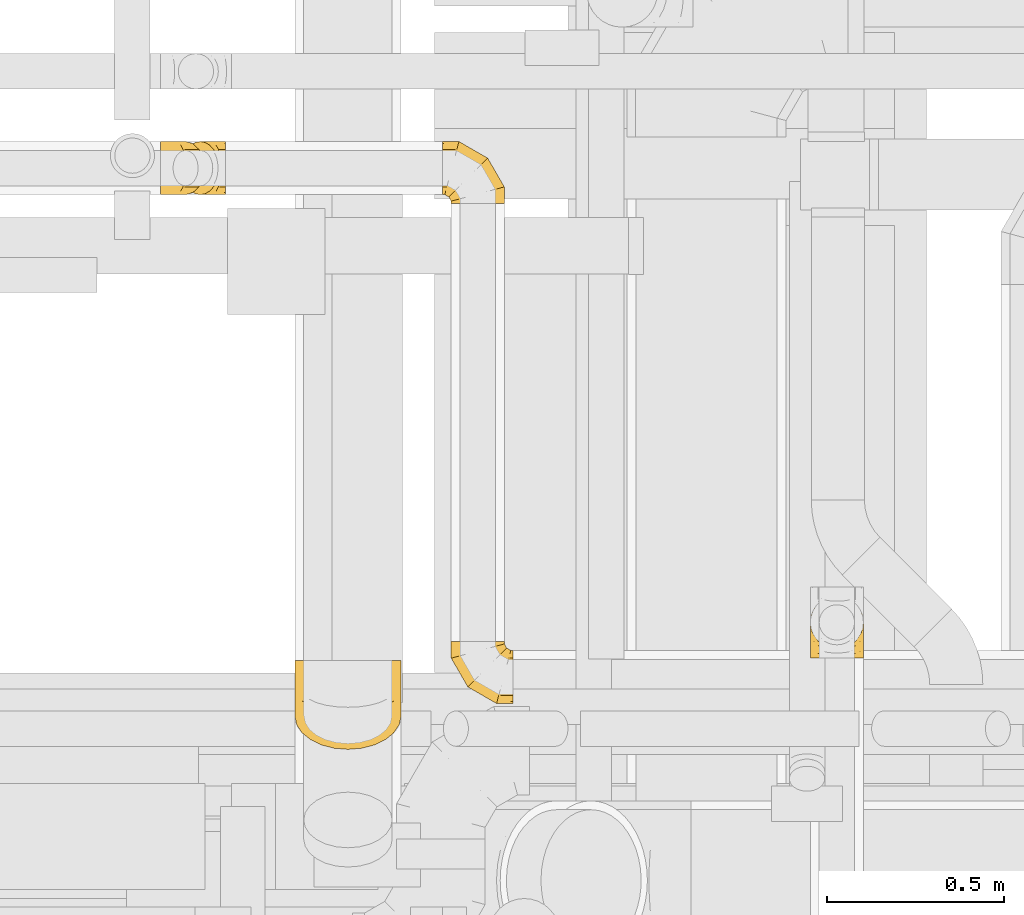
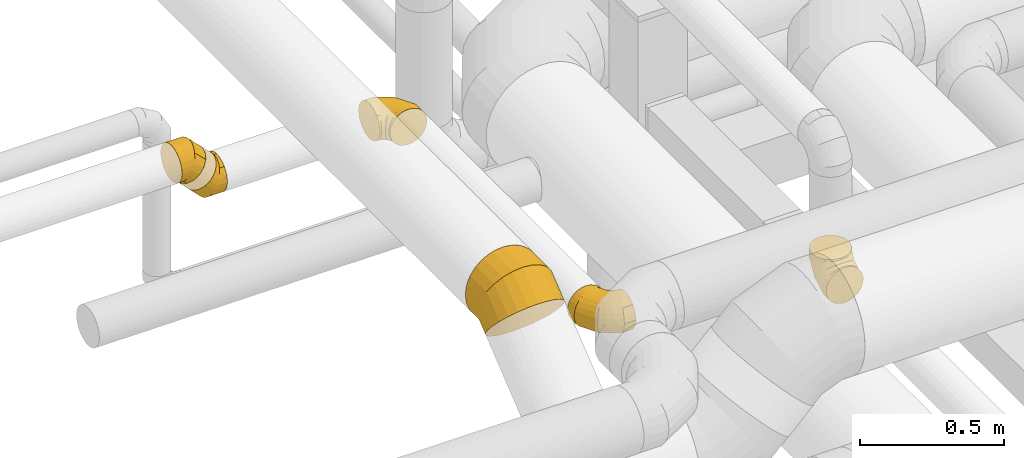
# One storey, part 18 of 337: 6 coverings.
"""IFC2X3 building model written with IfcOpenShell, lengths in millimetres."""

from ifc_helpers import new_model, entity, si_unit, converted_unit, derived_unit, direction, frame, origin, place, context, subcontext, project, spatial, faceted_brep, element, save


model = new_model("IFC2X3")

# Units and contexts
model_context = context("Model", 3, precision=0.01, world=origin(), true_north=direction((6.12303176911189e-17, 1.0)))
body_context = subcontext(model_context, "Body", "Model", "MODEL_VIEW")
ifc_project = project(units=[si_unit("LENGTHUNIT", "METRE", prefix="MILLI"), si_unit("AREAUNIT", "SQUARE_METRE"), si_unit("VOLUMEUNIT", "CUBIC_METRE"), converted_unit("PLANEANGLEUNIT", "DEGREE", entity("IfcRatioMeasure", 0.0174532925199433), si_unit("PLANEANGLEUNIT", "RADIAN"), dimensions=[0, 0, 0, 0, 0, 0, 0]), si_unit("MASSUNIT", "GRAM", prefix="KILO"), derived_unit("MASSDENSITYUNIT", [(si_unit("MASSUNIT", "GRAM", prefix="KILO"), 1), (si_unit("LENGTHUNIT", "METRE"), -3)]), derived_unit("MOMENTOFINERTIAUNIT", [(si_unit("LENGTHUNIT", "METRE"), 4)]), si_unit("TIMEUNIT", "SECOND"), si_unit("FREQUENCYUNIT", "HERTZ"), si_unit("THERMODYNAMICTEMPERATUREUNIT", "DEGREE_CELSIUS"), derived_unit("THERMALTRANSMITTANCEUNIT", [(si_unit("MASSUNIT", "GRAM", prefix="KILO"), 1), (si_unit("THERMODYNAMICTEMPERATUREUNIT", "KELVIN"), -1), (si_unit("TIMEUNIT", "SECOND"), -3)]), derived_unit("VOLUMETRICFLOWRATEUNIT", [(si_unit("LENGTHUNIT", "METRE"), 3), (si_unit("TIMEUNIT", "SECOND"), -1)]), derived_unit("MASSFLOWRATEUNIT", [(si_unit("MASSUNIT", "GRAM", prefix="KILO"), 1), (si_unit("TIMEUNIT", "SECOND"), -1)]), derived_unit("ROTATIONALFREQUENCYUNIT", [(si_unit("TIMEUNIT", "SECOND"), -1)]), si_unit("ELECTRICCURRENTUNIT", "AMPERE"), si_unit("ELECTRICVOLTAGEUNIT", "VOLT"), si_unit("POWERUNIT", "WATT"), si_unit("FORCEUNIT", "NEWTON", prefix="KILO"), si_unit("ILLUMINANCEUNIT", "LUX"), si_unit("LUMINOUSFLUXUNIT", "LUMEN"), si_unit("LUMINOUSINTENSITYUNIT", "CANDELA"), derived_unit("USERDEFINED", [(si_unit("MASSUNIT", "GRAM", prefix="KILO"), -1), (si_unit("LENGTHUNIT", "METRE"), -2), (si_unit("TIMEUNIT", "SECOND"), 3), (si_unit("LUMINOUSFLUXUNIT", "LUMEN"), 1)]), derived_unit("LINEARVELOCITYUNIT", [(si_unit("LENGTHUNIT", "METRE"), 1), (si_unit("TIMEUNIT", "SECOND"), -1)]), si_unit("PRESSUREUNIT", "PASCAL"), derived_unit("USERDEFINED", [(si_unit("LENGTHUNIT", "METRE"), -2), (si_unit("MASSUNIT", "GRAM", prefix="KILO"), 1), (si_unit("TIMEUNIT", "SECOND"), -2)]), derived_unit("LINEARFORCEUNIT", [(si_unit("MASSUNIT", "GRAM", prefix="KILO"), 1), (si_unit("LENGTHUNIT", "METRE"), 1), (si_unit("TIMEUNIT", "SECOND"), -2), (si_unit("LENGTHUNIT", "METRE"), -1)]), derived_unit("PLANARFORCEUNIT", [(si_unit("MASSUNIT", "GRAM", prefix="KILO"), 1), (si_unit("LENGTHUNIT", "METRE"), 1), (si_unit("TIMEUNIT", "SECOND"), -2), (si_unit("LENGTHUNIT", "METRE"), -2)])], contexts=[model_context])

# Site, building, storey
site_placement = place(None, origin())
site = spatial("IfcSite", under=ifc_project, at=site_placement, CompositionType="ELEMENT")
building_placement = place(site_placement, origin())
building = spatial("IfcBuilding", under=site, at=building_placement, CompositionType="ELEMENT")
storey_placement = place(building_placement, origin())
storey = spatial("IfcBuildingStorey", under=building, at=storey_placement, CompositionType="ELEMENT", Elevation=0.0)

# Coverings
covering_1_placement = place(storey_placement, frame((63106.04, 11685.99, 3366.08)))
element("IfcCovering", 1, at=covering_1_placement, inside=storey, PredefinedType="INSULATION", context=body_context, shape_type="Brep", body=[
    faceted_brep([(27.46, 117.46, 11.38), (33.21, 129.63, 17.13), (41.81, 137.76, 25.73), (50.42, 145.89, 34.33), (60.56, 148.74, 44.48), (70.71, 151.6, 54.63), (80.86, 148.74, 64.78), (91.01, 145.89, 74.92), (99.61, 137.76, 83.53), (108.21, 129.63, 92.13), (113.96, 117.46, 97.88), (119.71, 105.3, 103.62), (121.73, 90.95, 105.64), (123.74, 76.6, 107.66), (121.73, 62.24, 105.64), (119.71, 47.89, 103.62), (113.96, 35.73, 97.88), (108.21, 23.56, 92.13), (99.61, 15.43, 83.53), (91.01, 7.3, 74.92), (80.86, 4.45, 64.78), (70.71, 1.6, 54.63), (60.56, 4.45, 44.48), (50.42, 7.3, 34.33), (41.81, 15.43, 25.73), (33.21, 23.56, 17.13), (27.46, 35.73, 11.38), (21.71, 47.89, 5.63), (19.7, 62.24, 3.61), (18.69, 69.42, 2.6), (17.68, 76.6, 1.6), (18.69, 83.77, 2.6), (19.7, 90.95, 3.61), (21.71, 105.3, 5.63), (0.0, 39.1, 148.87), (0.0, 57.18, 156.36), (0.0, 76.6, 158.92), (0.0, 96.01, 156.36), (0.0, 114.1, 148.87), (0.0, 129.63, 136.95), (0.0, 141.55, 121.42), (0.0, 149.04, 103.33), (0.0, 151.6, 83.92), (0.0, 149.04, 64.51), (0.0, 141.55, 46.42), (0.0, 129.63, 30.88), (0.0, 114.1, 18.97), (0.0, 96.01, 11.47), (0.0, 76.6, 8.92), (0.0, 57.18, 11.47), (0.0, 39.1, 18.97), (0.0, 23.56, 30.88), (0.0, 11.64, 46.42), (0.0, 4.15, 64.51), (0.0, 1.6, 83.92), (0.0, 4.15, 103.33), (0.0, 11.64, 121.42), (0.0, 23.56, 136.95), (72.49, 76.6, 158.92), (71.43, 96.01, 156.36), (68.33, 114.1, 148.87), (63.39, 129.63, 136.95), (56.95, 141.55, 121.42), (49.46, 149.04, 103.33), (41.42, 151.6, 83.92), (33.38, 149.04, 64.51), (25.89, 141.55, 46.42), (19.45, 129.63, 30.88), (14.52, 114.1, 18.97), (12.97, 105.05, 15.22), (11.41, 96.01, 11.47), (10.36, 76.6, 8.92), (10.88, 86.3, 10.2), (11.41, 57.18, 11.47), (12.97, 48.14, 15.22), (14.52, 39.1, 18.97), (10.88, 66.89, 10.2), (19.45, 23.56, 30.88), (33.38, 4.15, 64.51), (41.42, 1.6, 83.92), (25.89, 11.64, 46.42), (49.46, 4.15, 103.33), (56.95, 11.64, 121.42), (63.39, 23.56, 136.95), (68.33, 39.1, 148.87), (71.43, 57.18, 156.36)], [[[0, 1, 2, 3, 4, 5, 6, 7, 8, 9, 10, 11, 12, 13, 14, 15, 16, 17, 18, 19, 20, 21, 22, 23, 24, 25, 26, 27, 28, 29, 30, 31, 32, 33]], [[34, 35, 36, 37, 38, 39, 40, 41, 42, 43, 44, 45, 46, 47, 48, 49, 50, 51, 52, 53, 54, 55, 56, 57]], [[36, 58, 59, 37]], [[37, 59, 60, 38]], [[61, 39, 38, 60]], [[39, 61, 62, 40]], [[40, 62, 63, 41]], [[64, 42, 41, 63]], [[65, 66, 44, 43]], [[64, 65, 43, 42]], [[67, 45, 44, 66]], [[46, 68, 69, 70, 47]], [[68, 46, 45, 67]], [[71, 48, 47, 70, 72]], [[50, 49, 73, 74, 75]], [[49, 48, 71, 76, 73]], [[51, 50, 75, 77]], [[78, 79, 54, 53]], [[80, 78, 53, 52]], [[77, 80, 52, 51]], [[55, 54, 79, 81]], [[56, 55, 81, 82]], [[82, 83, 57, 56]], [[35, 34, 84, 85]], [[36, 35, 85, 58]], [[83, 84, 34, 57]], [[58, 12, 59]], [[12, 58, 13]], [[10, 9, 61]], [[10, 61, 60]], [[60, 11, 10]], [[59, 11, 60]], [[8, 7, 62]], [[61, 8, 62]], [[12, 11, 59]], [[8, 61, 9]], [[5, 64, 6]], [[7, 63, 62]], [[64, 63, 6]], [[63, 7, 6]], [[65, 5, 4, 3]], [[1, 67, 2]], [[72, 32, 31]], [[66, 3, 2]], [[66, 65, 3]], [[71, 31, 30]], [[66, 2, 67]], [[71, 72, 31]], [[5, 65, 64]], [[32, 72, 70]], [[33, 70, 69, 68]], [[1, 0, 67]], [[67, 0, 68]], [[70, 33, 32]], [[68, 0, 33]], [[73, 28, 27]], [[26, 25, 77]], [[27, 75, 74, 73]], [[29, 28, 76]], [[29, 71, 30]], [[77, 75, 26]], [[24, 77, 25]], [[78, 23, 22, 21]], [[77, 24, 80]], [[71, 29, 76]], [[78, 80, 23]], [[78, 21, 79]], [[28, 73, 76]], [[75, 27, 26]], [[24, 23, 80]], [[82, 19, 18]], [[79, 20, 81]], [[19, 82, 81]], [[18, 83, 82]], [[16, 83, 17]], [[20, 19, 81]], [[17, 83, 18]], [[20, 79, 21]], [[83, 16, 84]], [[13, 58, 14]], [[15, 85, 84]], [[58, 85, 14]], [[85, 15, 14]], [[16, 15, 84]]]),
])
covering_2_placement = place(storey_placement, frame((63925.59, 10248.39, 3273.4)))
element("IfcCovering", 2, at=covering_2_placement, inside=storey, PredefinedType="INSULATION", context=body_context, shape_type="Brep", body=[
    faceted_brep([(176.6, 23.56, 129.63), (176.6, 15.43, 117.46), (176.6, 7.3, 105.3), (176.6, 4.45, 90.95), (176.6, 1.6, 76.6), (176.6, 4.45, 62.24), (176.6, 7.3, 47.89), (176.6, 15.43, 35.73), (176.6, 23.56, 23.56), (176.6, 35.73, 15.43), (176.6, 47.89, 7.3), (176.6, 62.24, 4.45), (176.6, 76.6, 1.6), (176.6, 90.95, 4.45), (176.6, 105.3, 7.3), (176.6, 117.46, 15.43), (176.6, 129.63, 23.56), (176.6, 137.76, 35.73), (176.6, 145.89, 47.89), (176.6, 148.74, 62.24), (176.6, 150.17, 69.42), (176.6, 151.6, 76.6), (176.6, 150.17, 83.77), (176.6, 148.74, 90.95), (176.6, 145.89, 105.3), (176.6, 137.76, 117.46), (176.6, 129.63, 129.63), (176.6, 117.46, 137.76), (176.6, 105.3, 145.89), (176.6, 90.95, 148.74), (176.6, 76.6, 151.6), (176.6, 62.24, 148.74), (176.6, 47.89, 145.89), (176.6, 35.73, 137.76), (4.15, 176.6, 57.18), (1.6, 176.6, 76.6), (4.15, 176.6, 96.01), (11.64, 176.6, 114.1), (23.56, 176.6, 129.63), (39.1, 176.6, 141.55), (57.18, 176.6, 149.04), (76.6, 176.6, 151.6), (96.01, 176.6, 149.04), (114.1, 176.6, 141.55), (129.63, 176.6, 129.63), (141.55, 176.6, 114.1), (149.04, 176.6, 96.01), (151.6, 176.6, 76.6), (149.04, 176.6, 57.18), (141.55, 176.6, 39.1), (129.63, 176.6, 23.56), (114.1, 176.6, 11.64), (96.01, 176.6, 4.15), (76.6, 176.6, 1.6), (57.18, 176.6, 4.15), (39.1, 176.6, 11.64), (23.56, 176.6, 23.56), (11.64, 176.6, 39.1), (1.6, 129.7, 76.6), (4.15, 130.39, 96.01), (11.64, 132.4, 114.1), (23.56, 135.59, 129.63), (39.1, 139.75, 141.55), (57.18, 144.6, 149.04), (76.6, 149.8, 151.6), (96.01, 155.0, 149.04), (114.1, 159.85, 141.55), (129.63, 164.01, 129.63), (141.55, 167.2, 114.1), (149.04, 169.21, 96.01), (151.6, 169.9, 76.6), (149.04, 169.21, 57.18), (141.55, 167.2, 39.1), (129.63, 164.01, 23.56), (96.01, 155.0, 4.15), (76.6, 149.8, 1.6), (114.1, 159.85, 11.64), (57.18, 144.6, 4.15), (39.1, 139.75, 11.64), (23.56, 135.59, 23.56), (11.64, 132.4, 39.1), (4.15, 130.39, 57.18), (48.49, 48.49, 76.6), (50.36, 50.36, 96.01), (55.84, 55.84, 114.1), (64.57, 64.57, 129.63), (75.94, 75.94, 141.55), (89.18, 89.18, 149.04), (103.39, 103.39, 151.6), (117.6, 117.6, 149.04), (130.84, 130.84, 141.55), (142.21, 142.21, 129.63), (150.94, 150.94, 114.1), (156.42, 156.42, 96.01), (158.29, 158.29, 76.6), (156.42, 156.42, 57.18), (150.94, 150.94, 39.1), (142.21, 142.21, 23.56), (117.6, 117.6, 4.15), (103.39, 103.39, 1.6), (130.84, 130.84, 11.64), (89.18, 89.18, 4.15), (75.94, 75.94, 11.64), (64.57, 64.57, 23.56), (55.84, 55.84, 39.1), (50.36, 50.36, 57.18), (129.7, 1.6, 76.6), (130.39, 4.15, 96.01), (132.4, 11.64, 114.1), (135.59, 23.56, 129.63), (139.75, 39.1, 141.55), (144.6, 57.18, 149.04), (149.8, 76.6, 151.6), (155.0, 96.01, 149.04), (159.85, 114.1, 141.55), (164.01, 129.63, 129.63), (167.2, 141.55, 114.1), (168.21, 145.29, 105.05), (169.21, 149.04, 96.01), (169.55, 150.32, 86.3), (169.9, 151.6, 76.6), (169.21, 149.04, 57.18), (168.21, 145.29, 48.14), (167.2, 141.55, 39.1), (169.55, 150.32, 66.89), (164.01, 129.63, 23.56), (155.0, 96.01, 4.15), (149.8, 76.6, 1.6), (159.85, 114.1, 11.64), (144.6, 57.18, 4.15), (139.75, 39.1, 11.64), (135.59, 23.56, 23.56), (132.4, 11.64, 39.1), (130.39, 4.15, 57.18)], [[[0, 1, 2, 3, 4, 5, 6, 7, 8, 9, 10, 11, 12, 13, 14, 15, 16, 17, 18, 19, 20, 21, 22, 23, 24, 25, 26, 27, 28, 29, 30, 31, 32, 33]], [[34, 35, 36, 37, 38, 39, 40, 41, 42, 43, 44, 45, 46, 47, 48, 49, 50, 51, 52, 53, 54, 55, 56, 57]], [[35, 58, 59, 36]], [[36, 59, 60, 37]], [[37, 60, 61, 38]], [[39, 62, 63, 40]], [[40, 63, 64, 41]], [[38, 61, 62, 39]], [[65, 66, 43, 42]], [[64, 65, 42, 41]], [[67, 44, 43, 66]], [[68, 69, 46, 45]], [[68, 45, 44, 67]], [[70, 47, 46, 69]], [[71, 72, 49, 48]], [[70, 71, 48, 47]], [[50, 49, 72, 73]], [[74, 75, 53, 52]], [[76, 74, 52, 51]], [[73, 76, 51, 50]], [[55, 54, 77, 78]], [[56, 55, 78, 79]], [[53, 75, 77, 54]], [[34, 57, 80, 81]], [[35, 34, 81, 58]], [[79, 80, 57, 56]], [[58, 82, 83, 59]], [[60, 59, 83, 84]], [[84, 85, 61, 60]], [[62, 61, 85, 86]], [[63, 62, 86, 87]], [[64, 63, 87, 88]], [[89, 90, 66, 65]], [[88, 89, 65, 64]], [[67, 66, 90, 91]], [[92, 93, 69, 68]], [[91, 92, 68, 67]], [[70, 69, 93, 94]], [[95, 96, 72, 71]], [[94, 95, 71, 70]], [[73, 72, 96, 97]], [[98, 99, 75, 74]], [[100, 98, 74, 76]], [[97, 100, 76, 73]], [[77, 75, 99, 101]], [[78, 77, 101, 102]], [[79, 78, 102, 103]], [[81, 80, 104, 105]], [[58, 81, 105, 82]], [[103, 104, 80, 79]], [[82, 106, 107, 83]], [[84, 83, 107, 108]], [[108, 109, 85, 84]], [[86, 85, 109, 110]], [[87, 86, 110, 111]], [[88, 87, 111, 112]], [[113, 114, 90, 89]], [[112, 113, 89, 88]], [[91, 90, 114, 115]], [[93, 92, 116, 117, 118]], [[115, 116, 92, 91]], [[94, 93, 118, 119, 120]], [[95, 121, 122, 123, 96]], [[94, 120, 124, 121, 95]], [[97, 96, 123, 125]], [[126, 127, 99, 98]], [[128, 126, 98, 100]], [[125, 128, 100, 97]], [[101, 99, 127, 129]], [[102, 101, 129, 130]], [[103, 102, 130, 131]], [[105, 104, 132, 133]], [[82, 105, 133, 106]], [[131, 132, 104, 103]], [[106, 3, 107]], [[111, 32, 31]], [[3, 106, 4]], [[0, 109, 1]], [[108, 2, 1]], [[107, 2, 108]], [[33, 32, 110]], [[108, 1, 109]], [[33, 109, 0]], [[30, 112, 31]], [[3, 2, 107]], [[112, 111, 31]], [[110, 32, 111]], [[109, 33, 110]], [[113, 30, 29, 28]], [[26, 115, 27]], [[119, 23, 22]], [[114, 28, 27]], [[114, 113, 28]], [[120, 22, 21]], [[114, 27, 115]], [[30, 113, 112]], [[120, 119, 22]], [[23, 119, 118]], [[24, 118, 117, 116]], [[26, 25, 115]], [[115, 25, 116]], [[118, 24, 23]], [[116, 25, 24]], [[121, 19, 18]], [[17, 16, 125]], [[18, 123, 122, 121]], [[20, 19, 124]], [[20, 120, 21]], [[125, 123, 17]], [[15, 125, 16]], [[126, 14, 13, 12]], [[125, 15, 128]], [[120, 20, 124]], [[126, 128, 14]], [[126, 12, 127]], [[19, 121, 124]], [[123, 18, 17]], [[15, 14, 128]], [[127, 11, 129]], [[8, 131, 9]], [[130, 10, 9]], [[129, 10, 130]], [[7, 131, 8]], [[11, 10, 129]], [[130, 9, 131]], [[11, 127, 12]], [[133, 6, 5]], [[131, 7, 132]], [[4, 106, 5]], [[6, 133, 132]], [[106, 133, 5]], [[7, 6, 132]]]),
])
covering_3_placement = place(storey_placement, frame((63902.18, 11662.59, 3273.4)))
element("IfcCovering", 3, at=covering_3_placement, inside=storey, PredefinedType="INSULATION", context=body_context, shape_type="Brep", body=[
    faceted_brep([(0.0, 169.29, 105.3), (0.0, 172.15, 90.95), (0.0, 175.0, 76.6), (0.0, 172.15, 62.24), (0.0, 169.29, 47.89), (0.0, 161.16, 35.73), (0.0, 153.03, 23.56), (0.0, 140.87, 15.43), (0.0, 128.7, 7.3), (0.0, 114.35, 4.45), (0.0, 100.0, 1.6), (0.0, 85.65, 4.45), (0.0, 71.3, 7.3), (0.0, 59.13, 15.43), (0.0, 46.97, 23.56), (0.0, 38.84, 35.73), (0.0, 30.71, 47.89), (0.0, 27.85, 62.24), (0.0, 26.43, 69.42), (0.0, 25.0, 76.6), (0.0, 26.43, 83.77), (0.0, 27.85, 90.95), (0.0, 30.71, 105.3), (0.0, 38.84, 117.46), (0.0, 46.97, 129.63), (0.0, 59.13, 137.76), (0.0, 71.3, 145.89), (0.0, 85.65, 148.74), (0.0, 100.0, 151.6), (0.0, 114.35, 148.74), (0.0, 128.7, 145.89), (0.0, 140.87, 137.76), (0.0, 153.03, 129.63), (0.0, 161.16, 117.46), (172.44, 0.0, 57.18), (175.0, 0.0, 76.6), (172.44, 0.0, 96.01), (164.95, 0.0, 114.1), (153.03, 0.0, 129.63), (137.5, 0.0, 141.55), (119.41, 0.0, 149.04), (100.0, 0.0, 151.6), (80.59, 0.0, 149.04), (62.5, 0.0, 141.55), (46.97, 0.0, 129.63), (35.05, 0.0, 114.1), (27.56, 0.0, 96.01), (25.0, 0.0, 76.6), (27.56, 0.0, 57.18), (35.05, 0.0, 39.1), (46.97, 0.0, 23.56), (62.5, 0.0, 11.64), (80.59, 0.0, 4.15), (100.0, 0.0, 1.6), (119.41, 0.0, 4.15), (137.5, 0.0, 11.64), (153.03, 0.0, 23.56), (164.95, 0.0, 39.1), (175.0, 46.89, 76.6), (172.44, 46.21, 96.01), (164.95, 44.2, 114.1), (153.03, 41.01, 129.63), (137.5, 36.84, 141.55), (119.41, 32.0, 149.04), (100.0, 26.79, 151.6), (80.59, 21.59, 149.04), (62.5, 16.75, 141.55), (46.97, 12.58, 129.63), (35.05, 9.39, 114.1), (27.56, 7.38, 96.01), (25.0, 6.7, 76.6), (27.56, 7.38, 57.18), (35.05, 9.39, 39.1), (46.97, 12.58, 23.56), (80.59, 21.59, 4.15), (100.0, 26.79, 1.6), (62.5, 16.75, 11.64), (119.41, 32.0, 4.15), (137.5, 36.84, 11.64), (153.03, 41.01, 23.56), (164.95, 44.2, 39.1), (172.44, 46.21, 57.18), (128.11, 128.11, 76.6), (126.24, 126.24, 96.01), (120.75, 120.75, 114.1), (112.03, 112.03, 129.63), (100.66, 100.66, 141.55), (87.42, 87.42, 149.04), (73.21, 73.21, 151.6), (58.99, 58.99, 149.04), (45.75, 45.75, 141.55), (34.38, 34.38, 129.63), (25.66, 25.66, 114.1), (20.17, 20.17, 96.01), (18.3, 18.3, 76.6), (20.17, 20.17, 57.18), (25.66, 25.66, 39.1), (34.38, 34.38, 23.56), (58.99, 58.99, 4.15), (73.21, 73.21, 1.6), (45.75, 45.75, 11.64), (87.42, 87.42, 4.15), (100.66, 100.66, 11.64), (112.03, 112.03, 23.56), (120.75, 120.75, 39.1), (126.24, 126.24, 57.18), (46.89, 175.0, 76.6), (46.21, 172.44, 96.01), (44.2, 164.95, 114.1), (41.01, 153.03, 129.63), (36.84, 137.5, 141.55), (32.0, 119.41, 149.04), (26.79, 100.0, 151.6), (21.59, 80.59, 149.04), (16.75, 62.5, 141.55), (12.58, 46.97, 129.63), (9.39, 35.05, 114.1), (8.39, 31.3, 105.05), (7.38, 27.56, 96.01), (7.04, 26.28, 86.3), (6.7, 25.0, 76.6), (7.38, 27.56, 57.18), (8.39, 31.3, 48.14), (9.39, 35.05, 39.1), (7.04, 26.28, 66.89), (12.58, 46.97, 23.56), (21.59, 80.59, 4.15), (26.79, 100.0, 1.6), (16.75, 62.5, 11.64), (32.0, 119.41, 4.15), (36.84, 137.5, 11.64), (41.01, 153.03, 23.56), (44.2, 164.95, 39.1), (46.21, 172.44, 57.18)], [[[0, 1, 2, 3, 4, 5, 6, 7, 8, 9, 10, 11, 12, 13, 14, 15, 16, 17, 18, 19, 20, 21, 22, 23, 24, 25, 26, 27, 28, 29, 30, 31, 32, 33]], [[34, 35, 36, 37, 38, 39, 40, 41, 42, 43, 44, 45, 46, 47, 48, 49, 50, 51, 52, 53, 54, 55, 56, 57]], [[35, 58, 59, 36]], [[36, 59, 60, 37]], [[37, 60, 61, 38]], [[39, 62, 63, 40]], [[40, 63, 64, 41]], [[38, 61, 62, 39]], [[65, 66, 43, 42]], [[64, 65, 42, 41]], [[67, 44, 43, 66]], [[68, 69, 46, 45]], [[68, 45, 44, 67]], [[70, 47, 46, 69]], [[71, 72, 49, 48]], [[70, 71, 48, 47]], [[50, 49, 72, 73]], [[74, 75, 53, 52]], [[76, 74, 52, 51]], [[73, 76, 51, 50]], [[55, 54, 77, 78]], [[56, 55, 78, 79]], [[53, 75, 77, 54]], [[34, 57, 80, 81]], [[35, 34, 81, 58]], [[79, 80, 57, 56]], [[58, 82, 83, 59]], [[60, 59, 83, 84]], [[84, 85, 61, 60]], [[62, 61, 85, 86]], [[63, 62, 86, 87]], [[64, 63, 87, 88]], [[89, 90, 66, 65]], [[88, 89, 65, 64]], [[67, 66, 90, 91]], [[92, 93, 69, 68]], [[91, 92, 68, 67]], [[70, 69, 93, 94]], [[95, 96, 72, 71]], [[94, 95, 71, 70]], [[73, 72, 96, 97]], [[98, 99, 75, 74]], [[100, 98, 74, 76]], [[97, 100, 76, 73]], [[77, 75, 99, 101]], [[78, 77, 101, 102]], [[79, 78, 102, 103]], [[81, 80, 104, 105]], [[58, 81, 105, 82]], [[103, 104, 80, 79]], [[82, 106, 107, 83]], [[84, 83, 107, 108]], [[108, 109, 85, 84]], [[86, 85, 109, 110]], [[87, 86, 110, 111]], [[88, 87, 111, 112]], [[113, 114, 90, 89]], [[112, 113, 89, 88]], [[91, 90, 114, 115]], [[93, 92, 116, 117, 118]], [[115, 116, 92, 91]], [[94, 93, 118, 119, 120]], [[95, 121, 122, 123, 96]], [[94, 120, 124, 121, 95]], [[97, 96, 123, 125]], [[126, 127, 99, 98]], [[128, 126, 98, 100]], [[125, 128, 100, 97]], [[101, 99, 127, 129]], [[102, 101, 129, 130]], [[103, 102, 130, 131]], [[105, 104, 132, 133]], [[82, 105, 133, 106]], [[131, 132, 104, 103]], [[106, 1, 107]], [[111, 30, 29]], [[1, 106, 2]], [[32, 109, 33]], [[108, 0, 33]], [[107, 0, 108]], [[31, 30, 110]], [[108, 33, 109]], [[31, 109, 32]], [[28, 112, 29]], [[1, 0, 107]], [[112, 111, 29]], [[110, 30, 111]], [[109, 31, 110]], [[113, 28, 27, 26]], [[24, 115, 25]], [[119, 21, 20]], [[114, 26, 25]], [[114, 113, 26]], [[120, 20, 19]], [[114, 25, 115]], [[28, 113, 112]], [[120, 119, 20]], [[21, 119, 118]], [[22, 118, 117, 116]], [[24, 23, 115]], [[115, 23, 116]], [[118, 22, 21]], [[116, 23, 22]], [[121, 17, 16]], [[15, 14, 125]], [[16, 123, 122, 121]], [[18, 17, 124]], [[18, 120, 19]], [[125, 123, 15]], [[13, 125, 14]], [[126, 12, 11, 10]], [[125, 13, 128]], [[120, 18, 124]], [[126, 128, 12]], [[126, 10, 127]], [[17, 121, 124]], [[123, 16, 15]], [[13, 12, 128]], [[127, 9, 129]], [[6, 131, 7]], [[130, 8, 7]], [[129, 8, 130]], [[5, 131, 6]], [[9, 8, 129]], [[130, 7, 131]], [[9, 127, 10]], [[133, 4, 3]], [[131, 5, 132]], [[2, 106, 3]], [[4, 133, 132]], [[106, 133, 3]], [[5, 4, 132]]]),
])
covering_4_placement = place(storey_placement, frame((63163.54, 11685.99, 3273.4)))
element("IfcCovering", 4, at=covering_4_placement, inside=storey, PredefinedType="INSULATION", context=body_context, shape_type="Brep", body=[
    faceted_brep([(125.34, 35.73, 137.76), (125.34, 23.56, 129.63), (125.34, 15.43, 117.46), (125.34, 7.3, 105.3), (125.34, 4.45, 90.95), (125.34, 1.6, 76.6), (125.34, 4.45, 62.24), (125.34, 7.3, 47.89), (125.34, 15.43, 35.73), (125.34, 23.56, 23.56), (125.34, 35.73, 15.43), (125.34, 47.89, 7.3), (125.34, 62.24, 4.45), (125.34, 76.6, 1.6), (125.34, 90.95, 4.45), (125.34, 105.3, 7.3), (125.34, 117.46, 15.43), (125.34, 129.63, 23.56), (125.34, 137.76, 35.73), (125.34, 145.89, 47.89), (125.34, 148.74, 62.24), (125.34, 151.6, 76.6), (125.34, 148.74, 90.95), (125.34, 145.89, 105.3), (125.34, 137.76, 117.46), (125.34, 129.63, 129.63), (125.34, 117.46, 137.76), (125.34, 105.3, 145.89), (125.34, 90.95, 148.74), (125.34, 83.77, 150.17), (125.34, 76.6, 151.6), (125.34, 69.42, 150.17), (125.34, 62.24, 148.74), (125.34, 47.89, 145.89), (8.7, 114.1, 59.96), (3.4, 96.01, 54.66), (1.6, 76.6, 52.85), (3.4, 57.18, 54.66), (8.7, 39.1, 59.96), (17.13, 23.56, 68.38), (28.11, 11.64, 79.37), (40.9, 4.15, 92.16), (54.63, 1.6, 105.88), (68.35, 4.15, 119.61), (81.14, 11.64, 132.4), (92.13, 23.56, 143.38), (100.56, 39.1, 151.81), (105.85, 57.18, 157.11), (107.66, 76.6, 158.92), (105.85, 96.01, 157.11), (100.56, 114.1, 151.81), (92.13, 129.63, 143.38), (81.14, 141.55, 132.4), (68.35, 149.04, 119.61), (54.63, 151.6, 105.88), (40.9, 149.04, 92.16), (28.11, 141.55, 79.37), (17.13, 129.63, 68.38), (52.85, 76.6, 1.6), (53.91, 57.18, 4.15), (57.01, 39.1, 11.64), (61.95, 23.56, 23.56), (68.38, 11.64, 39.1), (75.88, 4.15, 57.18), (83.92, 1.6, 76.6), (91.96, 4.15, 96.01), (99.45, 11.64, 114.1), (105.88, 23.56, 129.63), (110.82, 39.1, 141.55), (112.37, 48.14, 145.29), (113.93, 57.18, 149.04), (114.98, 76.6, 151.6), (114.45, 66.89, 150.32), (113.93, 96.01, 149.04), (112.37, 105.05, 145.29), (110.82, 114.1, 141.55), (114.45, 86.3, 150.32), (105.88, 129.63, 129.63), (91.96, 149.04, 96.01), (83.92, 151.6, 76.6), (99.45, 141.55, 114.1), (75.88, 149.04, 57.18), (68.38, 141.55, 39.1), (61.95, 129.63, 23.56), (57.01, 114.1, 11.64), (53.91, 96.01, 4.15)], [[[0, 1, 2, 3, 4, 5, 6, 7, 8, 9, 10, 11, 12, 13, 14, 15, 16, 17, 18, 19, 20, 21, 22, 23, 24, 25, 26, 27, 28, 29, 30, 31, 32, 33]], [[34, 35, 36, 37, 38, 39, 40, 41, 42, 43, 44, 45, 46, 47, 48, 49, 50, 51, 52, 53, 54, 55, 56, 57]], [[36, 58, 59, 37]], [[37, 59, 60, 38]], [[61, 39, 38, 60]], [[39, 61, 62, 40]], [[40, 62, 63, 41]], [[64, 42, 41, 63]], [[65, 66, 44, 43]], [[64, 65, 43, 42]], [[67, 45, 44, 66]], [[46, 68, 69, 70, 47]], [[68, 46, 45, 67]], [[71, 48, 47, 70, 72]], [[50, 49, 73, 74, 75]], [[49, 48, 71, 76, 73]], [[51, 50, 75, 77]], [[78, 79, 54, 53]], [[80, 78, 53, 52]], [[77, 80, 52, 51]], [[55, 54, 79, 81]], [[56, 55, 81, 82]], [[82, 83, 57, 56]], [[35, 34, 84, 85]], [[36, 35, 85, 58]], [[83, 84, 34, 57]], [[58, 12, 59]], [[12, 58, 13]], [[10, 9, 61]], [[10, 61, 60]], [[60, 11, 10]], [[59, 11, 60]], [[8, 7, 62]], [[61, 8, 62]], [[12, 11, 59]], [[8, 61, 9]], [[5, 64, 6]], [[7, 63, 62]], [[64, 63, 6]], [[63, 7, 6]], [[65, 5, 4, 3]], [[1, 67, 2]], [[72, 32, 31]], [[66, 3, 2]], [[66, 65, 3]], [[71, 31, 30]], [[66, 2, 67]], [[71, 72, 31]], [[5, 65, 64]], [[32, 72, 70]], [[33, 70, 69, 68]], [[1, 0, 67]], [[67, 0, 68]], [[70, 33, 32]], [[68, 0, 33]], [[73, 28, 27]], [[26, 25, 77]], [[27, 75, 74, 73]], [[29, 28, 76]], [[29, 71, 30]], [[77, 75, 26]], [[24, 77, 25]], [[78, 23, 22, 21]], [[77, 24, 80]], [[71, 29, 76]], [[78, 80, 23]], [[78, 21, 79]], [[28, 73, 76]], [[75, 27, 26]], [[24, 23, 80]], [[82, 19, 18]], [[79, 20, 81]], [[19, 82, 81]], [[18, 83, 82]], [[16, 83, 17]], [[20, 19, 81]], [[17, 83, 18]], [[20, 79, 21]], [[83, 16, 84]], [[13, 58, 14]], [[15, 85, 84]], [[58, 85, 14]], [[85, 15, 14]], [[16, 15, 84]]]),
])
covering_5_placement = place(storey_placement, frame((64940.15, 10379.14, 3023.4)))
element("IfcCovering", 5, at=covering_5_placement, inside=storey, PredefinedType="INSULATION", context=body_context, shape_type="Brep", body=[
    faceted_brep([(129.63, 153.03, 176.6), (117.46, 161.16, 176.6), (105.3, 169.29, 176.6), (90.95, 172.15, 176.6), (76.6, 175.0, 176.6), (62.24, 172.15, 176.6), (47.89, 169.29, 176.6), (35.73, 161.16, 176.6), (23.56, 153.03, 176.6), (15.43, 140.87, 176.6), (7.3, 128.7, 176.6), (4.45, 114.35, 176.6), (1.6, 100.0, 176.6), (4.45, 85.65, 176.6), (7.3, 71.3, 176.6), (15.43, 59.13, 176.6), (23.56, 46.97, 176.6), (35.73, 38.84, 176.6), (47.89, 30.71, 176.6), (62.24, 27.85, 176.6), (69.42, 26.43, 176.6), (76.6, 25.0, 176.6), (83.77, 26.43, 176.6), (90.95, 27.85, 176.6), (105.3, 30.71, 176.6), (117.46, 38.84, 176.6), (129.63, 46.97, 176.6), (137.76, 59.13, 176.6), (145.89, 71.3, 176.6), (148.74, 85.65, 176.6), (151.6, 100.0, 176.6), (148.74, 114.35, 176.6), (145.89, 128.7, 176.6), (137.76, 140.87, 176.6), (57.18, 0.0, 4.15), (76.6, 0.0, 1.6), (96.01, 0.0, 4.15), (114.1, 0.0, 11.64), (129.63, 0.0, 23.56), (141.55, 0.0, 39.1), (149.04, 0.0, 57.18), (151.6, 0.0, 76.6), (149.04, 0.0, 96.01), (141.55, 0.0, 114.1), (129.63, 0.0, 129.63), (114.1, 0.0, 141.55), (96.01, 0.0, 149.04), (76.6, 0.0, 151.6), (57.18, 0.0, 149.04), (39.1, 0.0, 141.55), (23.56, 0.0, 129.63), (11.64, 0.0, 114.1), (4.15, 0.0, 96.01), (1.6, 0.0, 76.6), (4.15, 0.0, 57.18), (11.64, 0.0, 39.1), (23.56, 0.0, 23.56), (39.1, 0.0, 11.64), (76.6, 46.89, 1.6), (96.01, 46.21, 4.15), (114.1, 44.2, 11.64), (129.63, 41.01, 23.56), (141.55, 36.84, 39.1), (149.04, 32.0, 57.18), (151.6, 26.79, 76.6), (149.04, 21.59, 96.01), (141.55, 16.75, 114.1), (129.63, 12.58, 129.63), (114.1, 9.39, 141.55), (96.01, 7.38, 149.04), (76.6, 6.7, 151.6), (57.18, 7.38, 149.04), (39.1, 9.39, 141.55), (23.56, 12.58, 129.63), (4.15, 21.59, 96.01), (1.6, 26.79, 76.6), (11.64, 16.75, 114.1), (4.15, 32.0, 57.18), (11.64, 36.84, 39.1), (23.56, 41.01, 23.56), (39.1, 44.2, 11.64), (57.18, 46.21, 4.15), (76.6, 128.11, 48.49), (96.01, 126.24, 50.36), (114.1, 120.75, 55.84), (129.63, 112.03, 64.57), (141.55, 100.66, 75.94), (149.04, 87.42, 89.18), (151.6, 73.21, 103.39), (149.04, 58.99, 117.6), (141.55, 45.75, 130.84), (129.63, 34.38, 142.21), (114.1, 25.66, 150.94), (96.01, 20.17, 156.42), (76.6, 18.3, 158.29), (57.18, 20.17, 156.42), (39.1, 25.66, 150.94), (23.56, 34.38, 142.21), (4.15, 58.99, 117.6), (1.6, 73.21, 103.39), (11.64, 45.75, 130.84), (4.15, 87.42, 89.18), (11.64, 100.66, 75.94), (23.56, 112.03, 64.57), (39.1, 120.75, 55.84), (57.18, 126.24, 50.36), (76.6, 175.0, 129.7), (96.01, 172.44, 130.39), (114.1, 164.95, 132.4), (129.63, 153.03, 135.59), (141.55, 137.5, 139.75), (149.04, 119.41, 144.6), (151.6, 100.0, 149.8), (149.04, 80.59, 155.0), (141.55, 62.5, 159.85), (129.63, 46.97, 164.01), (114.1, 35.05, 167.2), (105.05, 31.3, 168.21), (96.01, 27.56, 169.21), (86.3, 26.28, 169.55), (76.6, 25.0, 169.9), (57.18, 27.56, 169.21), (48.14, 31.3, 168.21), (39.1, 35.05, 167.2), (66.89, 26.28, 169.55), (23.56, 46.97, 164.01), (4.15, 80.59, 155.0), (1.6, 100.0, 149.8), (11.64, 62.5, 159.85), (4.15, 119.41, 144.6), (11.64, 137.5, 139.75), (23.56, 153.03, 135.59), (39.1, 164.95, 132.4), (57.18, 172.44, 130.39)], [[[0, 1, 2, 3, 4, 5, 6, 7, 8, 9, 10, 11, 12, 13, 14, 15, 16, 17, 18, 19, 20, 21, 22, 23, 24, 25, 26, 27, 28, 29, 30, 31, 32, 33]], [[34, 35, 36, 37, 38, 39, 40, 41, 42, 43, 44, 45, 46, 47, 48, 49, 50, 51, 52, 53, 54, 55, 56, 57]], [[35, 58, 59, 36]], [[36, 59, 60, 37]], [[37, 60, 61, 38]], [[39, 62, 63, 40]], [[40, 63, 64, 41]], [[38, 61, 62, 39]], [[65, 66, 43, 42]], [[64, 65, 42, 41]], [[67, 44, 43, 66]], [[68, 69, 46, 45]], [[68, 45, 44, 67]], [[70, 47, 46, 69]], [[71, 72, 49, 48]], [[70, 71, 48, 47]], [[50, 49, 72, 73]], [[74, 75, 53, 52]], [[76, 74, 52, 51]], [[73, 76, 51, 50]], [[55, 54, 77, 78]], [[56, 55, 78, 79]], [[53, 75, 77, 54]], [[34, 57, 80, 81]], [[35, 34, 81, 58]], [[79, 80, 57, 56]], [[58, 82, 83, 59]], [[60, 59, 83, 84]], [[84, 85, 61, 60]], [[62, 61, 85, 86]], [[63, 62, 86, 87]], [[64, 63, 87, 88]], [[89, 90, 66, 65]], [[88, 89, 65, 64]], [[67, 66, 90, 91]], [[92, 93, 69, 68]], [[91, 92, 68, 67]], [[70, 69, 93, 94]], [[95, 96, 72, 71]], [[94, 95, 71, 70]], [[73, 72, 96, 97]], [[98, 99, 75, 74]], [[100, 98, 74, 76]], [[97, 100, 76, 73]], [[77, 75, 99, 101]], [[78, 77, 101, 102]], [[79, 78, 102, 103]], [[81, 80, 104, 105]], [[58, 81, 105, 82]], [[103, 104, 80, 79]], [[82, 106, 107, 83]], [[84, 83, 107, 108]], [[108, 109, 85, 84]], [[86, 85, 109, 110]], [[87, 86, 110, 111]], [[88, 87, 111, 112]], [[113, 114, 90, 89]], [[112, 113, 89, 88]], [[91, 90, 114, 115]], [[93, 92, 116, 117, 118]], [[115, 116, 92, 91]], [[94, 93, 118, 119, 120]], [[95, 121, 122, 123, 96]], [[94, 120, 124, 121, 95]], [[97, 96, 123, 125]], [[126, 127, 99, 98]], [[128, 126, 98, 100]], [[125, 128, 100, 97]], [[101, 99, 127, 129]], [[102, 101, 129, 130]], [[103, 102, 130, 131]], [[105, 104, 132, 133]], [[82, 105, 133, 106]], [[131, 132, 104, 103]], [[106, 3, 107]], [[111, 32, 31]], [[3, 106, 4]], [[0, 109, 1]], [[108, 2, 1]], [[107, 2, 108]], [[33, 32, 110]], [[108, 1, 109]], [[33, 109, 0]], [[30, 112, 31]], [[3, 2, 107]], [[112, 111, 31]], [[110, 32, 111]], [[109, 33, 110]], [[113, 30, 29, 28]], [[26, 115, 27]], [[119, 23, 22]], [[114, 28, 27]], [[114, 113, 28]], [[120, 22, 21]], [[114, 27, 115]], [[30, 113, 112]], [[120, 119, 22]], [[23, 119, 118]], [[24, 118, 117, 116]], [[26, 25, 115]], [[115, 25, 116]], [[118, 24, 23]], [[116, 25, 24]], [[121, 19, 18]], [[17, 16, 125]], [[18, 123, 122, 121]], [[20, 19, 124]], [[20, 120, 21]], [[125, 123, 17]], [[15, 125, 16]], [[126, 14, 13, 12]], [[125, 15, 128]], [[120, 20, 124]], [[126, 128, 14]], [[126, 12, 127]], [[19, 121, 124]], [[123, 18, 17]], [[15, 14, 128]], [[127, 11, 129]], [[8, 131, 9]], [[130, 10, 9]], [[129, 10, 130]], [[7, 131, 8]], [[11, 10, 129]], [[130, 9, 131]], [[11, 127, 12]], [[133, 6, 5]], [[131, 7, 132]], [[4, 106, 5]], [[6, 133, 132]], [[106, 133, 5]], [[7, 6, 132]]]),
])
covering_6_placement = place(storey_placement, frame((63483.85, 10118.78, 3426.13)))
element("IfcCovering", 6, at=covering_6_placement, inside=storey, PredefinedType="INSULATION", context=body_context, shape_type="Brep", body=[
    faceted_brep([(190.42, 187.15, 5.57), (226.6, 177.72, 17.21), (257.66, 162.72, 35.74), (281.5, 143.17, 59.89), (296.48, 120.41, 88.0), (301.6, 95.98, 118.18), (296.48, 71.55, 148.35), (281.5, 48.79, 176.47), (257.66, 29.24, 200.61), (226.6, 14.24, 219.14), (190.42, 4.81, 230.79), (151.6, 1.6, 234.76), (112.77, 4.81, 230.79), (76.6, 14.24, 219.14), (45.53, 29.24, 200.61), (21.69, 48.79, 176.47), (6.71, 71.55, 148.35), (1.6, 95.98, 118.18), (6.71, 120.41, 88.0), (21.69, 143.17, 59.89), (45.53, 162.72, 35.74), (76.6, 177.72, 17.21), (112.77, 187.15, 5.57), (151.6, 190.36, 1.6), (112.77, 253.29, 318.76), (151.6, 253.29, 323.87), (190.42, 253.29, 318.76), (226.6, 253.29, 303.78), (257.66, 253.29, 279.94), (281.5, 253.29, 248.87), (296.48, 253.29, 212.7), (301.6, 253.29, 173.87), (296.48, 253.29, 135.05), (281.5, 253.29, 98.87), (257.66, 253.29, 67.81), (226.6, 253.29, 43.97), (190.42, 253.29, 28.98), (151.6, 253.29, 23.87), (112.77, 253.29, 28.98), (76.6, 253.29, 43.97), (45.53, 253.29, 67.81), (21.69, 253.29, 98.87), (6.71, 253.29, 135.05), (1.6, 253.29, 173.87), (6.71, 253.29, 212.7), (21.69, 253.29, 248.87), (45.53, 253.29, 279.94), (76.6, 253.29, 303.78), (151.6, 111.67, 323.87), (190.42, 113.48, 318.76), (226.6, 118.78, 303.78), (257.66, 127.22, 279.94), (281.5, 138.22, 248.87), (296.48, 151.03, 212.7), (301.6, 164.77, 173.87), (296.48, 178.52, 135.05), (281.5, 191.33, 98.87), (257.66, 202.33, 67.81), (190.42, 216.07, 28.98), (151.6, 217.88, 23.87), (226.6, 210.77, 43.97), (76.6, 210.77, 43.97), (45.53, 202.33, 67.81), (112.77, 216.07, 28.98), (6.71, 178.52, 135.05), (1.6, 164.77, 173.87), (21.69, 191.33, 98.87), (6.71, 151.03, 212.7), (21.69, 138.22, 248.87), (45.53, 127.22, 279.94), (76.6, 118.78, 303.78), (112.77, 113.48, 318.76)], [[[0, 1, 2, 3, 4, 5, 6, 7, 8, 9, 10, 11, 12, 13, 14, 15, 16, 17, 18, 19, 20, 21, 22, 23]], [[24, 25, 26, 27, 28, 29, 30, 31, 32, 33, 34, 35, 36, 37, 38, 39, 40, 41, 42, 43, 44, 45, 46, 47]], [[25, 48, 49, 26]], [[26, 49, 50, 27]], [[51, 28, 27, 50]], [[28, 51, 52, 29]], [[29, 52, 53, 30]], [[54, 31, 30, 53]], [[55, 56, 33, 32]], [[54, 55, 32, 31]], [[33, 56, 57, 34]], [[58, 59, 37, 36]], [[60, 58, 36, 35]], [[34, 57, 60, 35]], [[39, 61, 62, 40]], [[63, 61, 39, 38]], [[37, 59, 63, 38]], [[64, 65, 43, 42]], [[66, 64, 42, 41]], [[62, 66, 41, 40]], [[44, 43, 65, 67]], [[45, 44, 67, 68]], [[68, 69, 46, 45]], [[24, 47, 70, 71]], [[25, 24, 71, 48]], [[69, 70, 47, 46]], [[10, 9, 50, 49]], [[11, 10, 49, 48]], [[9, 8, 51, 50]], [[53, 52, 7, 6]], [[54, 53, 6, 5]], [[8, 7, 52, 51]], [[4, 3, 56, 55]], [[5, 4, 55, 54]], [[57, 56, 3, 2]], [[58, 60, 1, 0]], [[59, 58, 0, 23]], [[2, 1, 60, 57]], [[22, 21, 61, 63]], [[23, 22, 63, 59]], [[20, 62, 61, 21]], [[66, 19, 18, 64]], [[64, 18, 17, 65]], [[19, 66, 62, 20]], [[65, 17, 16, 67]], [[67, 16, 15, 68]], [[14, 69, 68, 15]], [[70, 13, 12, 71]], [[71, 12, 11, 48]], [[13, 70, 69, 14]]]),
])

save(model, "model.ifc")
